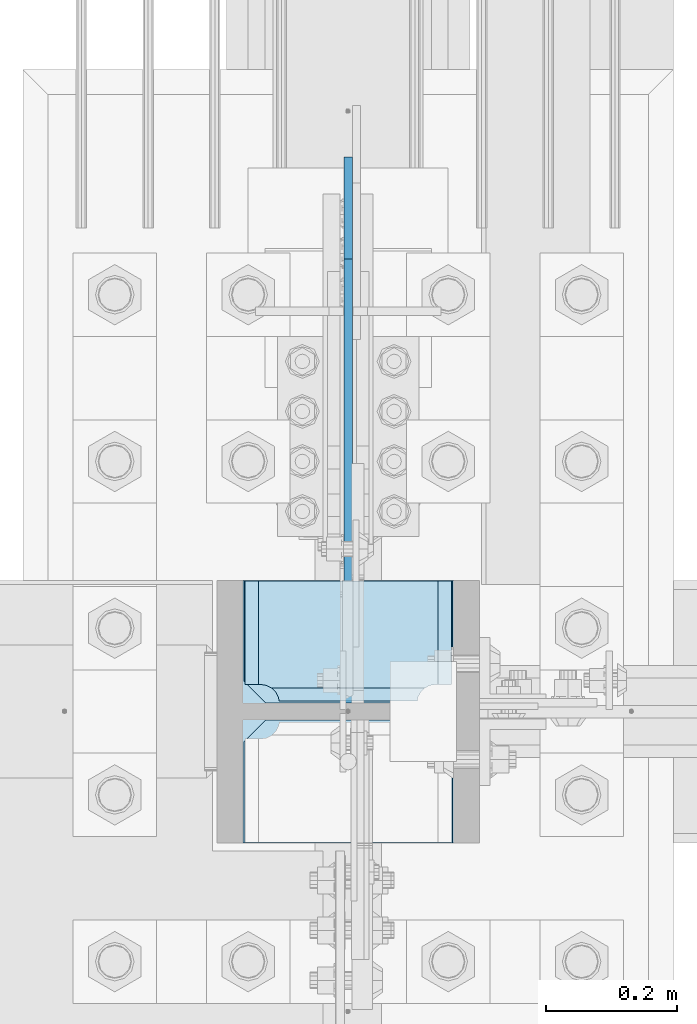
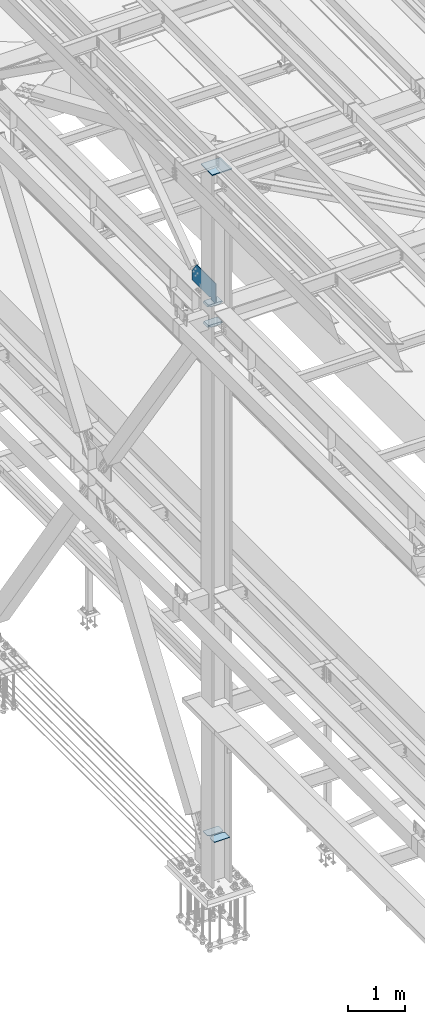
# One storey, part 3341 of 3843: 6 plates, 1 element without a shape of its own.
"""IFC2X3 building model written with IfcOpenShell, lengths in millimetres."""

from ifc_helpers import new_model, si_unit, frame, origin_with_axes, place, context, subcontext, project, spatial, faceted_brep, material, type_object, element, aggregate, save


model = new_model("IFC2X3")

# Units and contexts
model_context = context("Model", 3, precision=1e-05, world=origin_with_axes())
body_context = subcontext(model_context, "Body", "Model", "MODEL_VIEW")
ifc_project = project(units=[si_unit("LENGTHUNIT", "METRE", prefix="MILLI"), si_unit("AREAUNIT", "SQUARE_METRE"), si_unit("VOLUMEUNIT", "CUBIC_METRE"), si_unit("MASSUNIT", "GRAM", prefix="KILO"), si_unit("TIMEUNIT", "SECOND"), si_unit("PLANEANGLEUNIT", "RADIAN"), si_unit("SOLIDANGLEUNIT", "STERADIAN"), si_unit("THERMODYNAMICTEMPERATUREUNIT", "DEGREE_CELSIUS"), si_unit("LUMINOUSINTENSITYUNIT", "LUMEN")], contexts=[model_context])

# Site, building, storey
site_placement = place(None, origin_with_axes())
site = spatial("IfcSite", under=ifc_project, at=site_placement, CompositionType="ELEMENT")
building_placement = place(site_placement, origin_with_axes())
building = spatial("IfcBuilding", under=site, at=building_placement, Name="Undefined", CompositionType="ELEMENT")
storey_placement = place(building_placement, origin_with_axes())
storey = spatial("IfcBuildingStorey", under=building, at=storey_placement, Name="Undefined", CompositionType="ELEMENT", Elevation=0.0)

# Assembly, plates
assembly_placement = place(storey_placement, origin_with_axes())
assembly = element("IfcElementAssembly", 1, at=assembly_placement, inside=storey, Name="COLUMN", AssemblyPlace="NOTDEFINED", PredefinedType="RIGID_FRAME")
ifc_material = material(Name="STEEL/A572-50")
plate_type_1 = type_object("IfcPlateType", PredefinedType="NOTDEFINED")
plate_1_placement = place(assembly_placement, frame((36576.0000000077, 67284.6000000008, 42468.8000000014), z_axis=(0.0, 0.0, 1.0), x_axis=(0.0, 1.0, 0.0)))
plate_1 = element("IfcPlate", 2, at=plate_1_placement, type_object=plate_type_1, material=ifc_material, Name="PLATE", context=body_context, shape_type="Brep", body=[
    faceted_brep([(19.0499992370605, -6.34999999999854, 0.0), (0.0, -6.34999999999854, 19.0499992370605), (0.0, 6.34999999999854, 19.0499992370605), (19.0499992370605, 6.34999999999854, 0.0), (0.0, -6.34999999999854, 426.693425222751), (677.114659802028, -6.34999999999854, 426.693425222751), (677.114659802028, 6.34999999999854, 426.693425222751), (0.0, 6.34999999999854, 426.693425222751), (831.912255029587, -6.34999999999854, 209.514709617921), (831.912255029587, 6.34999999999854, 209.514709617921), (831.912255029587, -6.34999999999854, 12.6999999985928), (831.912255029587, 6.34999999999854, 12.6999999985928), (212.724999999176, -6.34999999999854, 12.6999999985928), (212.724999999176, 6.34999999999854, 12.6999999985928), (212.724999999176, -6.34999999999854, 25.4000001893219), (212.724999999176, 6.34999999999854, 25.4000001893219), (211.758270076585, -6.34999999999854, 30.2600797073683), (211.758270076585, 6.34999999999854, 30.2600797073683), (209.005256176111, -6.34999999999854, 34.3802561755219), (209.005256176111, 6.34999999999854, 34.3802561755219), (204.885079707958, -6.34999999999854, 37.1332700759958), (204.885079707958, 6.34999999999854, 37.1332700759958), (200.025000189911, -6.34999999999854, 38.099999998587), (200.025000189911, 6.34999999999854, 38.099999998587), (174.624999808439, -6.34999999999854, 38.099999998587), (174.624999808439, 6.34999999999854, 38.099999998587), (169.764920290392, -6.34999999999854, 37.1332700759958), (169.764920290392, 6.34999999999854, 37.1332700759958), (165.644743822239, -6.34999999999854, 34.3802561755219), (165.644743822239, 6.34999999999854, 34.3802561755219), (162.891729921765, -6.34999999999854, 30.2600797073683), (162.891729921765, 6.34999999999854, 30.2600797073683), (161.924999999173, -6.34999999999854, 25.4000001893219), (161.924999999173, 6.34999999999854, 25.4000001893219), (161.924999999173, -6.34999999999854, 0.0), (161.924999999173, 6.34999999999854, 0.0)], [[[0, 1, 2, 3]], [[4, 5, 6, 7]], [[5, 8, 9, 6]], [[9, 8, 10, 11]], [[10, 12, 13, 11]], [[14, 15, 13, 12]], [[16, 17, 15, 14]], [[18, 19, 17, 16]], [[20, 21, 19, 18]], [[22, 23, 21, 20]], [[24, 25, 23, 22]], [[26, 27, 25, 24]], [[28, 29, 27, 26]], [[30, 31, 29, 28]], [[32, 33, 31, 30]], [[34, 35, 33, 32]], [[35, 34, 0, 3]], [[7, 6, 9, 11, 13, 15, 17, 19, 21, 23, 25, 27, 29, 31, 33, 35, 3, 2]], [[4, 7, 2, 1]], [[34, 32, 30, 28, 26, 24, 22, 20, 18, 16, 14, 12, 10, 8, 5, 4, 1, 0]]]),
])
plate_type_2 = type_object("IfcPlateType", PredefinedType="NOTDEFINED")
plate_2_placement = place(assembly_placement, frame((36736.3375, 67471.1313, 42013.1875), z_axis=(-1.0, 0.0, 0.0), x_axis=(0.0, -1.0, 0.0)))
plate_2 = element("IfcPlate", 3, at=plate_2_placement, type_object=plate_type_2, material=ifc_material, Name="PLATE", context=body_context, shape_type="Brep", body=[
    faceted_brep([(169.7353359673, 6.12986484301655, 50.1051604685563), (163.413638768514, 17.0792088240414, 43.7834632697632), (163.192342336726, 17.4625000000015, 43.3491445679101), (163.192342336726, 17.4625000000015, 277.325855432093), (163.413638768514, 17.0792088240414, 276.89153673024), (169.7353359673, 6.12986484301655, 270.569839531447), (177.701139149984, -7.66711346669035, 266.511060084209), (183.356300047686, -17.4625000000015, 265.61537059048), (183.356300047686, -17.4625000000015, 55.059629409523), (177.701139149984, -7.66711346669035, 54.1639399157939), (0.0, 17.4625000000015, 297.336542336721), (0.0, -17.4625000000015, 317.500500047689), (157.956299237063, -17.4625000000015, 317.500500047689), (157.956299237063, 17.4625000000015, 297.336542336721), (157.956299237063, 17.4625000000015, 23.3384576632816), (157.956299237063, -17.4625000000015, 3.17449995231436), (0.0, -17.4625000000015, 3.17449995232164), (0.0, 17.4625000000015, 23.3384576632816), (157.956299237063, -17.4625000000015, 293.687500762942), (157.956299237063, 17.4625000000015, 293.687500762942), (159.354859321276, -17.4625000000015, 284.857339912916), (159.354859321276, 17.4625000000015, 284.857339912916), (163.413638768514, -17.4625000000015, 276.89153673024), (169.7353359673, -17.4625000000015, 270.569839531447), (177.701139149984, -17.4625000000015, 266.511060084209), (177.701139149984, -17.4625000000015, 54.1639399157939), (169.7353359673, -17.4625000000015, 50.1051604685563), (163.413638768514, -17.4625000000015, 43.7834632697632), (159.354859321276, -17.4625000000015, 35.8176600870866), (159.354859321276, 17.4625000000015, 35.8176600870866), (157.956299237063, -17.4625000000015, 26.9874992370605), (157.956299237063, 17.4625000000015, 26.9874992370605)], [[[0, 1, 2, 3, 4, 5, 6, 7, 8, 9]], [[10, 11, 12, 13]], [[14, 15, 16, 17]], [[17, 16, 11, 10]], [[18, 19, 13, 12]], [[18, 20, 21, 19]], [[21, 20, 22, 4, 3]], [[22, 23, 5, 4]], [[23, 24, 6, 5]], [[24, 7, 6]], [[25, 9, 8]], [[25, 26, 0, 9]], [[26, 27, 1, 0]], [[27, 28, 29, 2, 1]], [[28, 30, 31, 29]], [[31, 30, 15, 14]], [[29, 31, 14, 17, 10, 13, 19, 21, 3, 2]], [[15, 30, 28, 27, 26, 25, 8, 7, 24, 23, 22, 20, 18, 12, 11, 16]]]),
])
plate_3_placement = place(assembly_placement, frame((36736.3375, 67471.1313, 42451.3375), z_axis=(-1.0, 0.0, 0.0), x_axis=(0.0, -1.0, 0.0)))
plate_3 = element("IfcPlate", 4, at=plate_3_placement, type_object=plate_type_2, material=ifc_material, Name="PLATE", context=body_context, shape_type="Brep", body=[
    faceted_brep([(169.7353359673, 6.12954035346047, 50.1051604685563), (163.413638768514, 17.0792088240414, 43.7834632697632), (163.192342336726, 17.4625000000015, 43.3491445679101), (163.192342336726, 17.4625000000015, 277.325855432093), (163.413638768514, 17.0792088240414, 276.89153673024), (169.7353359673, 6.12954035346047, 270.569839531447), (177.701139149984, -7.6678330078139, 266.511060084209), (183.356300047686, -17.4625000000015, 265.61537059048), (183.356300047686, -17.4625000000015, 55.059629409523), (177.701139149984, -7.6678330078139, 54.1639399157939), (0.0, 17.4625000000015, 297.336542336721), (0.0, -17.4625000000015, 317.500500047689), (157.956299237063, -17.4625000000015, 317.500500047689), (157.956299237063, 17.4625000000015, 297.336542336721), (157.956299237063, 17.4625000000015, 23.3384576632816), (157.956299237063, -17.4625000000015, 3.17449995231436), (0.0, -17.4625000000015, 3.17449995232164), (0.0, 17.4625000000015, 23.3384576632816), (157.956299237063, -17.4625000000015, 293.687500762942), (157.956299237063, 17.4625000000015, 293.687500762942), (159.354859321276, -17.4625000000015, 284.857339912916), (159.354859321276, 17.4625000000015, 284.857339912916), (163.413638768514, -17.4625000000015, 276.89153673024), (169.7353359673, -17.4625000000015, 270.569839531447), (177.701139149984, -17.4625000000015, 266.511060084209), (177.701139149984, -17.4625000000015, 54.1639399157939), (169.7353359673, -17.4625000000015, 50.1051604685563), (163.413638768514, -17.4625000000015, 43.7834632697632), (159.354859321276, -17.4625000000015, 35.8176600870866), (159.354859321276, 17.4625000000015, 35.8176600870866), (157.956299237063, -17.4625000000015, 26.9874992370605), (157.956299237063, 17.4625000000015, 26.9874992370605)], [[[0, 1, 2, 3, 4, 5, 6, 7, 8, 9]], [[10, 11, 12, 13]], [[14, 15, 16, 17]], [[17, 16, 11, 10]], [[18, 19, 13, 12]], [[18, 20, 21, 19]], [[21, 20, 22, 4, 3]], [[22, 23, 5, 4]], [[23, 24, 6, 5]], [[24, 7, 6]], [[25, 9, 8]], [[25, 26, 0, 9]], [[26, 27, 1, 0]], [[27, 28, 29, 2, 1]], [[28, 30, 31, 29]], [[31, 30, 15, 14]], [[29, 31, 14, 17, 10, 13, 19, 21, 3, 2]], [[15, 30, 28, 27, 26, 25, 8, 7, 24, 23, 22, 20, 18, 12, 11, 16]]]),
])
plate_type_3 = type_object("IfcPlateType", PredefinedType="NOTDEFINED")
plate_4_placement = place(assembly_placement, frame((36734.75, 67284.6, 31130.1545707849), z_axis=(0.0, 1.0, 0.0), x_axis=(-1.0, 0.0, 0.0)))
plate_4 = element("IfcPlate", 5, at=plate_4_placement, type_object=plate_type_3, material=ifc_material, Name="CB_COL", context=body_context, shape_type="Brep", body=[
    faceted_brep([(0.0, -6.34999999999854, 33.3375015258789), (0.0, -6.34999999999854, 187.324999999997), (0.0, 6.34999999999854, 187.324999999997), (0.0, 6.34999999999854, 33.3375015258789), (317.5, -6.34999999999854, 187.324999999997), (317.5, 6.34999999999854, 187.324999999997), (317.499999999985, -6.34999999999854, 33.3375015258789), (317.499999999985, 6.34999999999854, 33.3375015258789), (284.162498474107, -6.34999999999854, 0.0), (284.162498474107, 6.34999999999854, 0.0), (33.3375015258789, -6.34999999999854, 0.0), (33.3375015258789, 6.34999999999854, 0.0)], [[[0, 1, 2, 3]], [[1, 4, 5, 2]], [[4, 6, 7, 5]], [[6, 8, 9, 7]], [[8, 10, 11, 9]], [[10, 0, 3, 11]], [[5, 7, 9, 11, 3, 2]], [[10, 8, 6, 4, 1, 0]]]),
])
plate_5_placement = place(assembly_placement, frame((36734.75, 67259.2, 31130.1545707849), z_axis=(0.0, -1.0, 0.0), x_axis=(-1.0, 0.0, 0.0)))
plate_5 = element("IfcPlate", 6, at=plate_5_placement, type_object=plate_type_3, material=ifc_material, Name="CB_COL", context=body_context, shape_type="Brep", body=[
    faceted_brep([(0.0, -6.34999999999854, 33.3375015258789), (0.0, -6.34999999999854, 187.324999999997), (0.0, 6.34999999999854, 187.324999999997), (0.0, 6.34999999999854, 33.3375015258789), (317.5, -6.34999999999854, 187.324999999997), (317.5, 6.34999999999854, 187.324999999997), (317.499999999985, -6.34999999999854, 33.3375015258789), (317.499999999985, 6.34999999999854, 33.3375015258789), (284.162498474107, -6.34999999999854, 0.0), (284.162498474107, 6.34999999999854, 0.0), (33.3375015258789, -6.34999999999854, 0.0), (33.3375015258789, 6.34999999999854, 0.0)], [[[0, 1, 2, 3]], [[1, 4, 5, 2]], [[4, 6, 7, 5]], [[6, 8, 9, 7]], [[8, 10, 11, 9]], [[10, 0, 3, 11]], [[5, 7, 9, 11, 3, 2]], [[10, 8, 6, 4, 1, 0]]]),
])
plate_type_4 = type_object("IfcPlateType", PredefinedType="NOTDEFINED")
plate_6_placement = place(assembly_placement, frame((36776.025, 67071.8745, 45410.1324263148), z_axis=(-1.0, 0.0, 0.0), x_axis=(0.0, 1.0, 0.0)))
plate_6 = element("IfcPlate", 7, at=plate_6_placement, type_object=plate_type_4, material=ifc_material, Name="PLATE", context=body_context, shape_type="Brep", body=[
    faceted_brep([(0.0, -9.52500000000146, 0.0), (0.000500003050547093, -9.52500000000146, 400.049999996474), (0.000500003050547093, 9.52500000000146, 400.049999996474), (0.0, 9.52500000000146, 0.0), (400.050500003053, -9.52500000000146, 400.049999995354), (400.050500003053, 9.52500000000146, 400.049999995354), (400.049999999988, -9.52500000000146, -1.1423253454268e-09), (400.049999999988, 9.52500000000146, -1.1423253454268e-09)], [[[0, 1, 2, 3]], [[1, 4, 5, 2]], [[4, 6, 7, 5]], [[6, 0, 3, 7]], [[5, 7, 3, 2]], [[6, 4, 1, 0]]]),
])
aggregate(assembly, [plate_4, plate_5, plate_6, plate_2, plate_3, plate_1])

save(model, "model.ifc")
